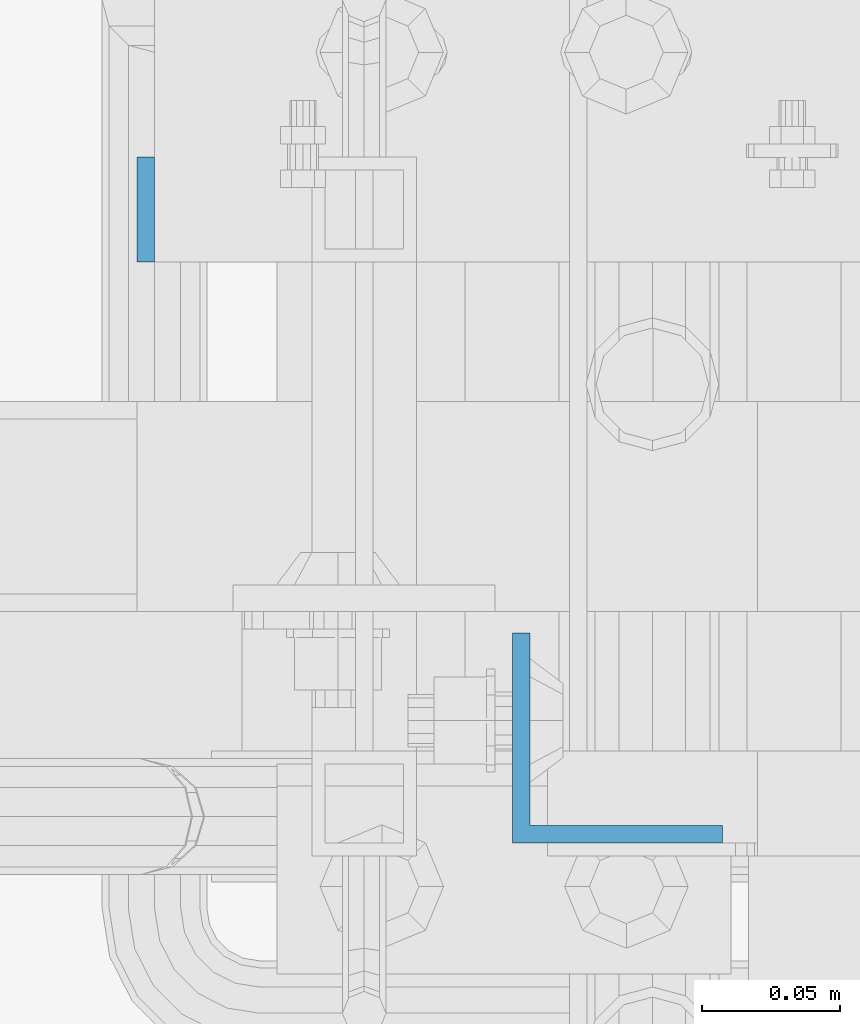
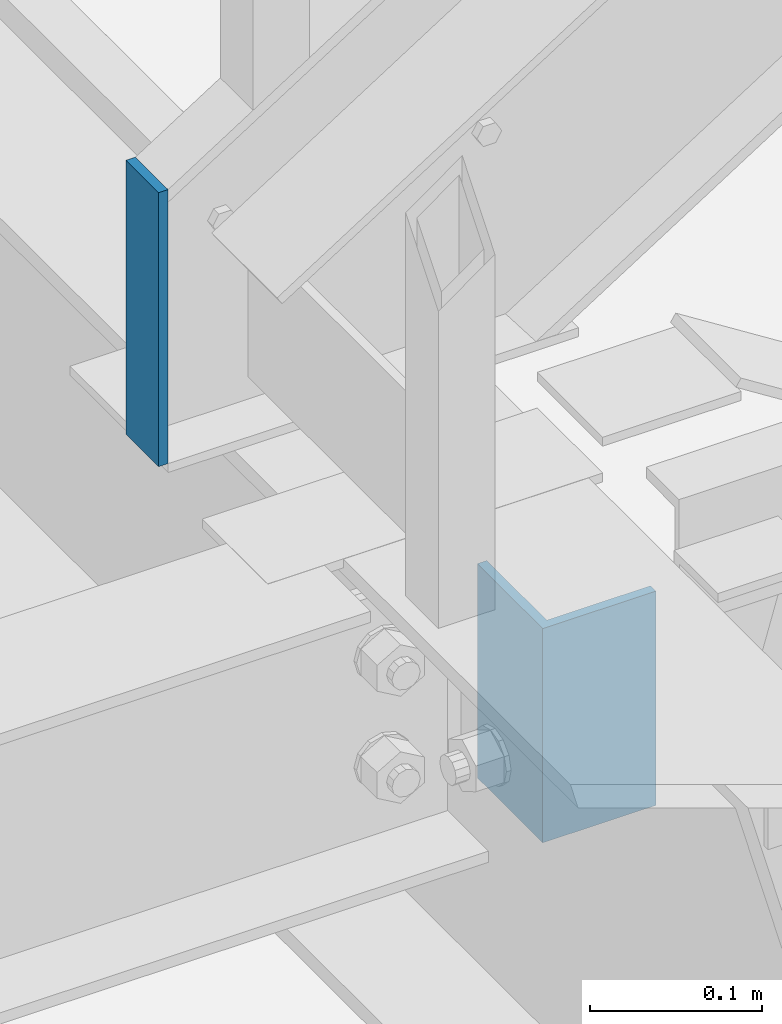
# One storey, part 821 of 1876: 2 columns, 2 elements without a shape of their own.
"""IFC2X3 building model written with IfcOpenShell, lengths in millimetres."""

from ifc_helpers import new_model, si_unit, frame, origin_with_axes, place, context, subcontext, project, spatial, faceted_brep, material, type_object, element, aggregate, save


model = new_model("IFC2X3")

# Units and contexts
model_context = context("Model", 3, precision=1e-05, world=origin_with_axes())
body_context = subcontext(model_context, "Body", "Model", "MODEL_VIEW")
ifc_project = project(units=[si_unit("LENGTHUNIT", "METRE", prefix="MILLI"), si_unit("AREAUNIT", "SQUARE_METRE"), si_unit("VOLUMEUNIT", "CUBIC_METRE"), si_unit("MASSUNIT", "GRAM", prefix="KILO"), si_unit("TIMEUNIT", "SECOND"), si_unit("PLANEANGLEUNIT", "RADIAN"), si_unit("SOLIDANGLEUNIT", "STERADIAN"), si_unit("THERMODYNAMICTEMPERATUREUNIT", "DEGREE_CELSIUS"), si_unit("LUMINOUSINTENSITYUNIT", "LUMEN")], contexts=[model_context])

# Site, building, storey
site_placement = place(None, origin_with_axes())
site = spatial("IfcSite", under=ifc_project, at=site_placement, CompositionType="ELEMENT")
building_placement = place(site_placement, origin_with_axes())
building = spatial("IfcBuilding", under=site, at=building_placement, Name="Undefined", CompositionType="ELEMENT")
storey_placement = place(building_placement, origin_with_axes())
storey = spatial("IfcBuildingStorey", under=building, at=storey_placement, Name="Undefined", CompositionType="ELEMENT", Elevation=0.0)

# Assembly, column
assembly_1_placement = place(storey_placement, origin_with_axes())
assembly_1 = element("IfcElementAssembly", 1, at=assembly_1_placement, inside=storey, Name="STRINGER", AssemblyPlace="NOTDEFINED", PredefinedType="RIGID_FRAME")
ifc_material = material(Name="STEEL/A36")
column_type_1 = type_object("IfcColumnType", Name="L3X3X1/4", PredefinedType="NOTDEFINED")
column_1_placement = place(assembly_1_placement, frame((1768.475, -5926.13750113562, 4949.82500000023), z_axis=(1.0, 0.0, 0.0), x_axis=(0.0, 0.0, 1.0)))
column_1 = element("IfcColumn", 2, at=column_1_placement, type_object=column_type_1, material=ifc_material, Name="ANGLE", ObjectType="L3X3X1/4", context=body_context, shape_type="Brep", body=[
    faceted_brep([(0.0, 38.1000000000004, -38.1), (0.0, 38.1000000000004, 38.1), (152.4, 38.1000000000004, 38.1), (152.4, 38.1000000000004, -38.1), (0.0, 31.75, 38.1000000000004), (152.4, 31.75, 38.0999999999999), (0.0, 31.75, -31.75), (152.4, 31.75, -31.75), (0.0, -38.1000000000004, -31.75), (152.4, -38.1000000000004, -31.75), (0.0, -38.1000000000004, -38.1), (152.4, -38.1000000000004, -38.1)], [[[0, 1, 2, 3]], [[1, 4, 5, 2]], [[4, 6, 7, 5]], [[6, 8, 9, 7]], [[8, 10, 11, 9]], [[10, 0, 3, 11]], [[5, 7, 9, 11, 3, 2]], [[10, 8, 6, 4, 1, 0]]]),
])
aggregate(assembly_1, [column_1])

assembly_2_placement = place(storey_placement, origin_with_axes())
assembly_2 = element("IfcElementAssembly", 3, at=assembly_2_placement, inside=storey, Name="STRINGER", AssemblyPlace="NOTDEFINED", PredefinedType="RIGID_FRAME")
column_type_2 = type_object("IfcColumnType", PredefinedType="NOTDEFINED")
column_2_placement = place(assembly_2_placement, frame((1597.02499918269, -5734.05000113592, 5137.14999991051), z_axis=(0.0, -1.0, 0.0), x_axis=(0.0, 0.0, 1.0)))
column_2 = element("IfcColumn", 4, at=column_2_placement, type_object=column_type_2, material=ifc_material, Name="PLATE", context=body_context, shape_type="Brep", body=[
    faceted_brep([(0.0, 3.17500000000018, -19.0500000000002), (0.0, 3.17500000000018, 19.0499992370605), (194.918224246349, 3.17499999999995, 19.0500000000002), (194.918224246349, 3.17499999999995, -19.0500000000002), (0.0, -3.17500000000018, 19.0499992370605), (194.918224246349, -3.17499999999995, 19.0500000000002), (0.0, -3.17500000000018, -19.0500000000002), (194.918224246349, -3.17499999999995, -19.0500000000002)], [[[0, 1, 2, 3]], [[1, 4, 5, 2]], [[4, 6, 7, 5]], [[6, 0, 3, 7]], [[5, 7, 3, 2]], [[6, 4, 1, 0]]]),
])
aggregate(assembly_2, [column_2])

save(model, "model.ifc")
